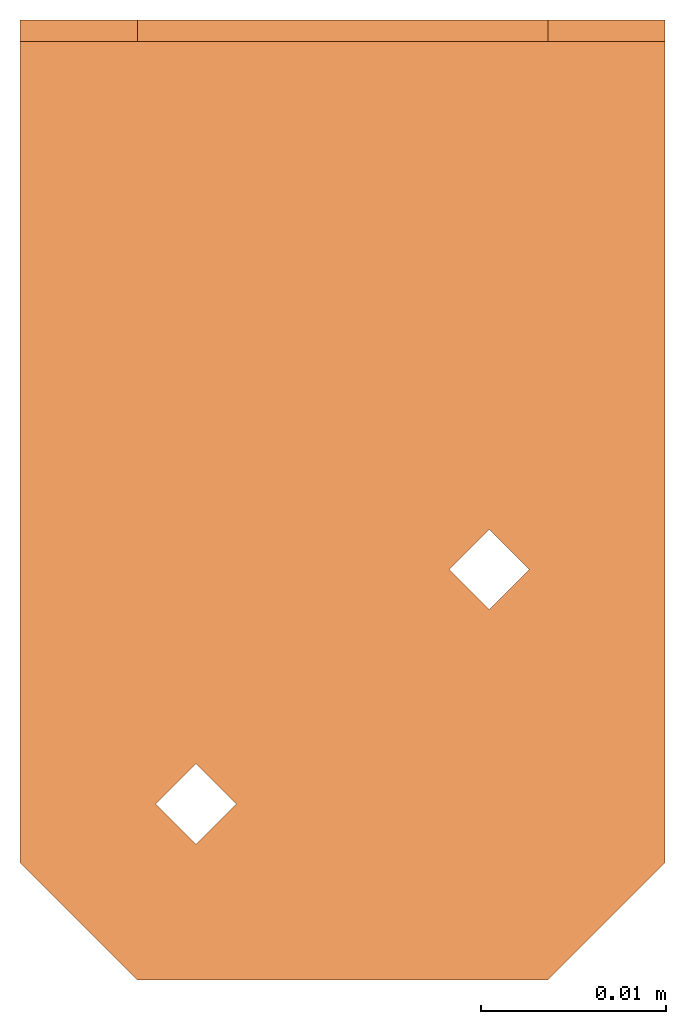
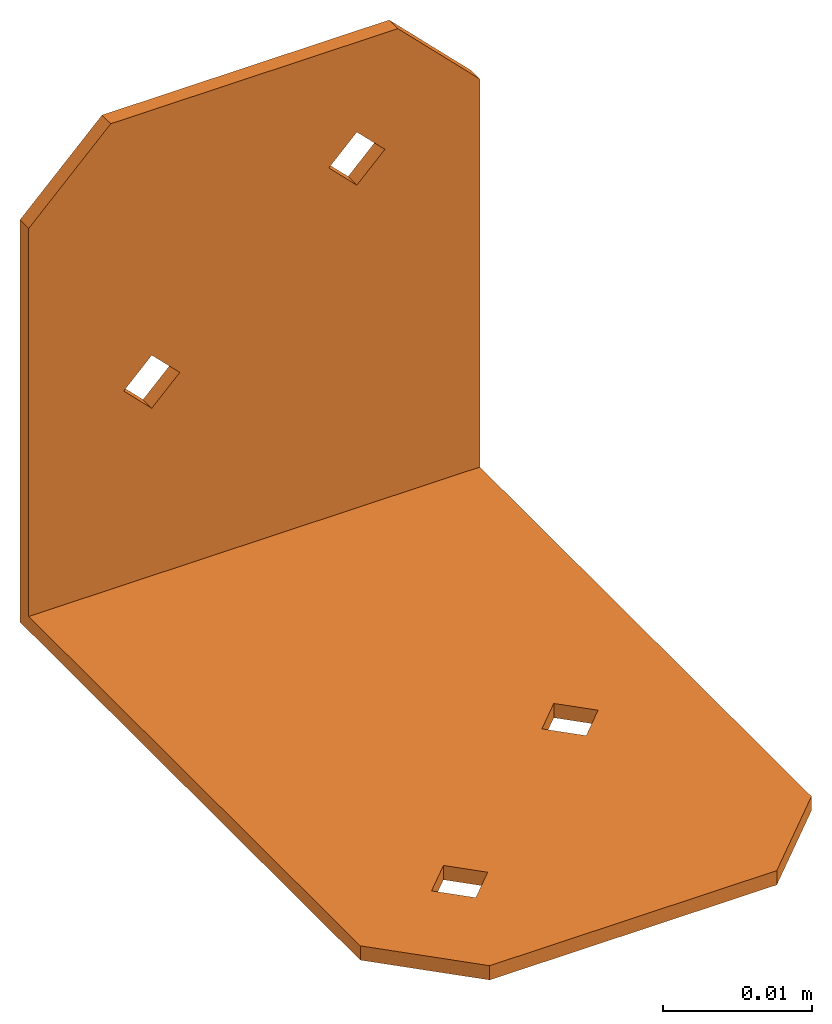
# One storey: 1 proxy.
"""IFC2X3 building model written with IfcOpenShell, lengths in millimetres."""

from ifc_helpers import new_model, entity, si_unit, converted_unit, derived_unit, direction, origin, place, context, subcontext, project, spatial, faceted_brep, source, transform, mapped, material, element, save


model = new_model("IFC2X3")

# Units and contexts
model_context = context("Model", 3, precision=0.01, world=origin(), true_north=direction((6.12303176911189e-17, 1.0)))
context_of_model = context(None, 3, precision=0.01, world=origin(), true_north=direction((6.12303176911189e-17, 1.0)))
body_context = subcontext(model_context, "Body", "Model", "MODEL_VIEW")
ifc_project = project(units=[si_unit("LENGTHUNIT", "METRE", prefix="MILLI"), si_unit("AREAUNIT", "SQUARE_METRE"), si_unit("VOLUMEUNIT", "CUBIC_METRE"), converted_unit("PLANEANGLEUNIT", "DEGREE", entity("IfcRatioMeasure", 0.0174532925199433), si_unit("PLANEANGLEUNIT", "RADIAN"), dimensions=[0, 0, 0, 0, 0, 0, 0]), si_unit("MASSUNIT", "GRAM", prefix="KILO"), si_unit("TIMEUNIT", "SECOND"), si_unit("FREQUENCYUNIT", "HERTZ"), si_unit("THERMODYNAMICTEMPERATUREUNIT", "DEGREE_CELSIUS"), derived_unit("THERMALTRANSMITTANCEUNIT", [(si_unit("MASSUNIT", "GRAM", prefix="KILO"), 1), (si_unit("THERMODYNAMICTEMPERATUREUNIT", "KELVIN"), -1), (si_unit("TIMEUNIT", "SECOND"), -3)]), derived_unit("VOLUMETRICFLOWRATEUNIT", [(si_unit("LENGTHUNIT", "METRE"), 3), (si_unit("TIMEUNIT", "SECOND"), -1)]), si_unit("ELECTRICCURRENTUNIT", "AMPERE"), si_unit("ELECTRICVOLTAGEUNIT", "VOLT"), si_unit("POWERUNIT", "WATT"), si_unit("FORCEUNIT", "NEWTON"), si_unit("ILLUMINANCEUNIT", "LUX"), si_unit("LUMINOUSFLUXUNIT", "LUMEN"), si_unit("LUMINOUSINTENSITYUNIT", "CANDELA"), si_unit("PRESSUREUNIT", "PASCAL")], contexts=[model_context, context_of_model])

# Site, building, storey
site_placement = place(None, origin())
site = spatial("IfcSite", under=ifc_project, at=site_placement, CompositionType="ELEMENT")
building_placement = place(site_placement, origin())
building = spatial("IfcBuilding", under=site, at=building_placement, CompositionType="ELEMENT")
storey_placement = place(building_placement, origin())
storey = spatial("IfcBuildingStorey", under=building, at=storey_placement, Name="Level 1", CompositionType="ELEMENT", Elevation=0.0)

# Proxy
ifc_material = material(Name="Galvanised")
shared_shape = source(origin(), body_context, "Body", "Brep", [
    faceted_brep([(-7.93750000000009, -40.2717, 0.0), (-5.76580000000009, -42.4434, 0.0), (-5.76580000000008, -42.4434, 0.584199999999936), (-5.76580000000008, -42.4434, 1.16839999999993), (-7.93750000000008, -40.2717, 1.16839999999994), (-10.1092000000001, -42.4434, 0.584199999999953), (-10.1092000000001, -42.4434, 0.0), (-10.1092000000001, -42.4434, 1.16839999999996), (7.93749999999991, -27.5717, 0.0), (10.1091999999999, -29.7434, 0.0), (10.1091999999999, -29.7434, 0.584199999999919), (10.1091999999999, -29.7434, 1.16839999999991), (7.93749999999992, -27.5717, 1.16839999999991), (5.76579999999992, -29.7434, 0.584199999999919), (5.76579999999992, -29.7434, 0.0), (5.76579999999992, -29.7434, 1.16839999999994), (-7.9375, 0.0, 19.2151), (-5.76580000000001, 0.0, 17.0434), (-5.76580000000001, -0.58420000000008, 17.0434), (-5.76580000000001, -1.16840000000007, 17.0434), (-7.9375, -1.16840000000007, 19.2151), (-10.1092, -0.584200000000063, 17.0434), (-10.1092, 0.0, 17.0434), (-10.1092, -1.16840000000008, 17.0434), (7.93750000000004, 0.0, 31.9151), (10.1092, 0.0, 29.7434), (10.1092, -0.58420000000008, 29.7434), (10.1092, -1.16840000000008, 29.7434), (7.93750000000004, -1.16840000000008, 31.9151), (5.76580000000004, -0.58420000000008, 29.7434), (5.76580000000004, 0.0, 29.7434), (5.76580000000004, -1.1684000000001, 29.7434), (-17.4625000000001, 0.0, 0.0), (7.93749999999992, -31.9151, 0.0), (11.1124999999999, -51.9684, 0.0), (17.4624999999999, -45.6184000000001, 0.0), (17.4624999999999, 0.0, 0.0), (-7.93750000000008, -44.6151, 0.0), (-11.1125000000001, -51.9684, 0.0), (-17.4625000000001, -45.6184, 0.0), (-11.1124999999999, 0.0, 39.2684), (-17.4625, 0.0, 32.9184000000001), (-7.93750000000002, 0.0, 14.8717), (7.93750000000003, 0.0, 27.5717), (17.4625, 0.0, 32.9183999999999), (11.1125000000001, 0.0, 39.2684), (-11.1124999999999, -1.1684000000001, 39.2684), (7.93750000000003, -1.16840000000008, 27.5717), (11.1125000000001, -1.1684000000001, 39.2684), (17.4625, -1.16840000000009, 32.9183999999999), (17.4624999999999, -1.16840000000004, 1.16839999999992), (-17.4625, -1.16840000000009, 32.9184000000001), (-17.4625000000001, -1.16840000000004, 1.16840000000006), (-7.93750000000002, -1.16840000000006, 14.8717), (-17.4625000000001, -45.6184, 1.16839999999998), (-11.1125000000001, -51.9684, 1.16839999999994), (-7.93750000000008, -44.6151, 1.16839999999995), (11.1124999999999, -51.9684, 1.16839999999987), (7.93749999999992, -31.9151, 1.16839999999992), (17.4624999999999, -45.6184, 1.16839999999986)], [[[0, 1, 2, 3, 4]], [[5, 6, 0, 4, 7]], [[8, 9, 10, 11, 12]], [[13, 14, 8, 12, 15]], [[16, 17, 18, 19, 20]], [[21, 22, 16, 20, 23]], [[24, 25, 26, 27, 28]], [[29, 30, 24, 28, 31]], [[14, 0, 32]], [[8, 14, 32]], [[1, 0, 14]], [[1, 14, 33]], [[1, 33, 34]], [[34, 33, 35]], [[35, 33, 9]], [[9, 8, 36]], [[35, 9, 36]], [[32, 36, 8]], [[34, 37, 1]], [[34, 38, 37]], [[38, 39, 37]], [[39, 32, 0]], [[39, 6, 37]], [[0, 6, 39]], [[16, 40, 30]], [[41, 40, 16]], [[16, 30, 17]], [[41, 16, 22]], [[41, 22, 32]], [[42, 32, 22]], [[36, 32, 42]], [[42, 17, 36]], [[43, 36, 17]], [[44, 36, 43]], [[24, 30, 40]], [[24, 40, 45]], [[24, 45, 44]], [[44, 25, 24]], [[43, 25, 44]], [[43, 17, 30]], [[31, 46, 20]], [[46, 31, 28]], [[19, 31, 20]], [[31, 19, 47]], [[48, 46, 28]], [[49, 48, 28]], [[28, 27, 49]], [[49, 27, 47]], [[19, 50, 47]], [[47, 50, 49]], [[20, 46, 51]], [[23, 20, 51]], [[52, 23, 51]], [[23, 52, 53]], [[53, 52, 50]], [[50, 19, 53]], [[54, 39, 38, 55]], [[52, 4, 15]], [[4, 52, 54]], [[52, 15, 12]], [[12, 50, 52]], [[54, 7, 4]], [[56, 7, 54]], [[56, 54, 55]], [[56, 55, 57]], [[3, 56, 57]], [[57, 58, 3]], [[59, 58, 57]], [[11, 58, 59]], [[50, 11, 59]], [[50, 12, 11]], [[58, 15, 3]], [[15, 4, 3]], [[55, 38, 34, 57]], [[57, 34, 35, 59]], [[40, 41, 51, 46]], [[48, 45, 40, 46]], [[48, 49, 44, 45]], [[59, 35, 36, 44, 49, 50]], [[29, 31, 47, 43, 30]], [[43, 47, 27, 26, 25]], [[21, 23, 53, 42, 22]], [[42, 53, 19, 18, 17]], [[13, 15, 58, 33, 14]], [[33, 58, 11, 10, 9]], [[5, 7, 56, 37, 6]], [[37, 56, 3, 2, 1]], [[41, 32, 39, 54, 52, 51]]]),
])
proxy_placement = place(storey_placement, origin())
element("IfcBuildingElementProxy", 1, at=proxy_placement, inside=storey, material=ifc_material, Name="A21:A21", ObjectType="A21", CompositionType="ELEMENT", context=body_context, shape_type="MappedRepresentation", body=[
    mapped(shared_shape, transform((0.0, 0.0, 0.0), scale=1.0)),
])

save(model, "model.ifc")
